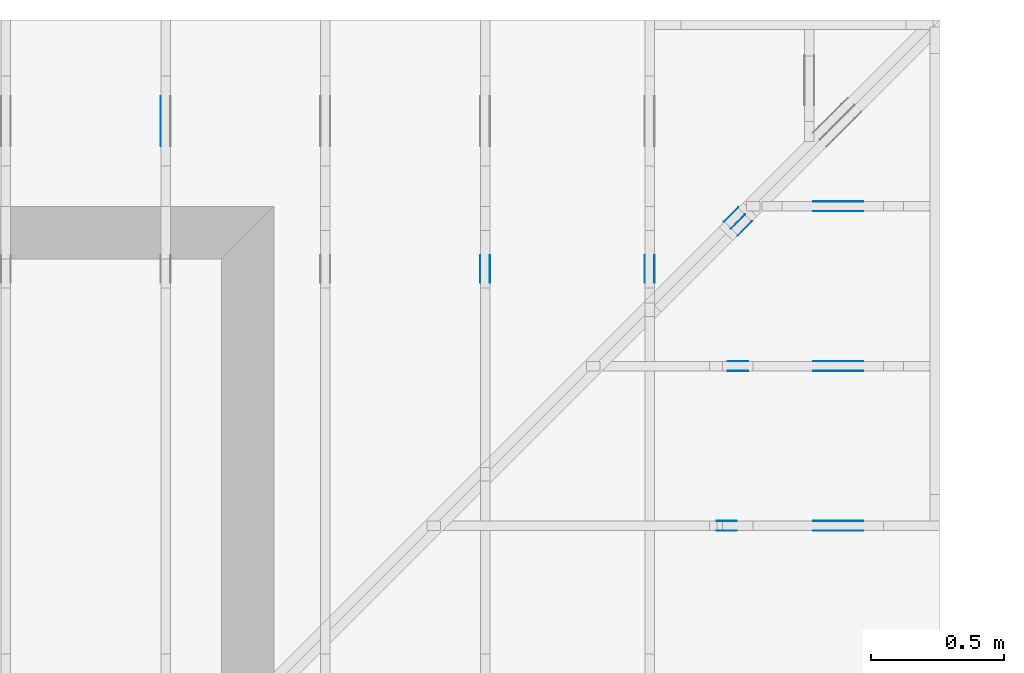
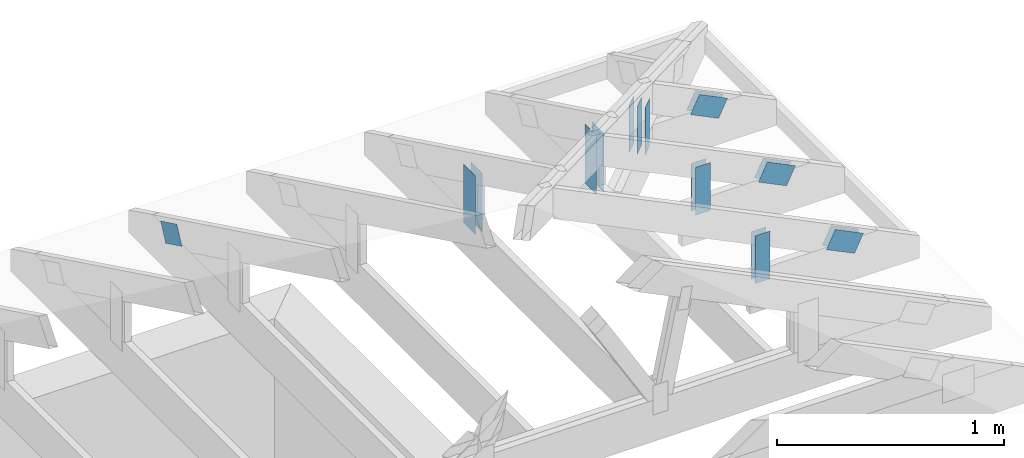
# One storey, part 138 of 159: 19 plates, 7 elements without a shape of their own.
"""IFC2X3 building model written with IfcOpenShell, lengths in millimetres."""

import ifcopenshell
import ifcopenshell.guid

model = None  # the IFC model being written
_history = None  # IfcOwnerHistory: only IFC2X3 demands one
_inside = {}  # id of a spatial element -> (the spatial element, [elements in it])
_under = {}  # id of a project, library or spatial element -> (it, [spatial elements below it])
_declared = {}  # id of a project -> (the project, [libraries it declares])
_typed = {}  # id of a type object -> (the type object, [elements of that type])
_made_of = {}  # id of a material, layer set ... -> (it, [elements and type objects made of it])


def new_model(schema):
    """Start an empty IFC model of exactly this schema.

    Asked for "IFC4X3", IfcOpenShell would pick the latest addendum, in which some entities
    have other attributes; the version numbers below select the first issue.
    IFC2X3 requires an IfcOwnerHistory on every rooted entity: one is made here for all.
    """
    global model, _history
    if schema == "IFC4X3":
        model = ifcopenshell.file(schema_version=(4, 3, 0, 0))
    else:
        model = ifcopenshell.file(schema=schema)
    _inside.clear()
    _under.clear()
    _declared.clear()
    _typed.clear()
    _made_of.clear()
    _history = None
    if model.schema == "IFC2X3":
        org = make("IfcOrganization", Name="unknown")
        user = make(
            "IfcPersonAndOrganization",
            ThePerson=make("IfcPerson", FamilyName="unknown"),
            TheOrganization=org,
        )
        app = make(
            "IfcApplication",
            ApplicationDeveloper=org,
            Version="unknown",
            ApplicationFullName="unknown",
            ApplicationIdentifier="unknown",
        )
        _history = make(
            "IfcOwnerHistory",
            OwningUser=user,
            OwningApplication=app,
            ChangeAction="ADDED",
            CreationDate=0,
        )
    return model


def make(cls, **values):
    """One entity of the class cls with the attributes given. An attribute that is None is left unset."""
    return model.create_entity(
        cls, **{name: value for name, value in values.items() if value is not None}
    )


def rooted(cls, **values):
    """An entity with a GlobalId (a new one), such as an element, a storey or a relation."""
    return make(cls, GlobalId=ifcopenshell.guid.new(), OwnerHistory=_history, **values)


def si_unit(unit_type, name, prefix=None):
    """IfcSIUnit, for example si_unit("LENGTHUNIT", "METRE", prefix="MILLI")."""
    return make("IfcSIUnit", UnitType=unit_type, Prefix=prefix, Name=name)


def assignment(units):
    """IfcUnitAssignment: the units of a project."""
    return None if units is None else make("IfcUnitAssignment", Units=units)


def point(xyz):
    """IfcCartesianPoint."""
    return None if xyz is None else make("IfcCartesianPoint", Coordinates=xyz)


def direction(xyz):
    """IfcDirection."""
    return None if xyz is None else make("IfcDirection", DirectionRatios=xyz)


def frame(location, z_axis=None, x_axis=None):
    """IfcAxis2Placement3D, a coordinate frame: its origin and axes. An axis left out is left unset."""
    return make(
        "IfcAxis2Placement3D",
        Location=point(location),
        Axis=direction(z_axis),
        RefDirection=direction(x_axis),
    )


def frame_2d(location, x_axis=None):
    """IfcAxis2Placement2D, a coordinate frame in the plane: its origin and x axis."""
    return make(
        "IfcAxis2Placement2D", Location=point(location), RefDirection=direction(x_axis)
    )


def origin():
    """The frame at (0, 0, 0) with its axes left unset."""
    return frame((0.0, 0.0, 0.0))


def origin_with_axes():
    """The frame at (0, 0, 0) with the z axis (0, 0, 1) and the x axis (1, 0, 0) written out."""
    return frame((0.0, 0.0, 0.0), z_axis=(0.0, 0.0, 1.0), x_axis=(1.0, 0.0, 0.0))


def origin_2d():
    """The frame at (0, 0) in the plane with its x axis left unset."""
    return frame_2d((0.0, 0.0))


def place(relative_to, where):
    """IfcLocalPlacement: puts the frame where relative to a parent placement (None: the world)."""
    return make(
        "IfcLocalPlacement", PlacementRelTo=relative_to, RelativePlacement=where
    )


def context(
    kind, dimensions, precision=None, world=None, true_north=None, identifier=None
):
    """IfcGeometricRepresentationContext, for example the 3D "Model" context."""
    return make(
        "IfcGeometricRepresentationContext",
        ContextIdentifier=identifier,
        ContextType=kind,
        CoordinateSpaceDimension=dimensions,
        Precision=precision,
        WorldCoordinateSystem=world,
        TrueNorth=true_north,
    )


def project(units=None, contexts=None):
    """IfcProject with its units and contexts."""
    return rooted(
        "IfcProject",
        Name="project",
        RepresentationContexts=contexts,
        UnitsInContext=assignment(units),
    )


def spatial(cls, under=None, at=None, **own):
    """A site, building, storey or space (cls), placed at a placement, below another one or the project."""
    s = rooted(cls, ObjectPlacement=at, **own)
    if under is not None:
        _under.setdefault(under.id(), (under, []))[1].append(s)
    return s


def faces_of(points, faces, orient=None, outer=None):
    """IfcFace entities. A face is a list of loops; a loop is a list of indices into points, from 0.

    orient and outer hold one flag for each loop. By default every Orientation is true, the
    first loop of a face is its IfcFaceOuterBound and the others are IfcFaceBound.
    """
    made = []
    for i, loops in enumerate(faces):
        bounds = []
        for j, loop in enumerate(loops):
            is_outer = j == 0 if outer is None else outer[i][j]
            bounds.append(
                make(
                    "IfcFaceOuterBound" if is_outer else "IfcFaceBound",
                    Bound=make("IfcPolyLoop", Polygon=[points[k] for k in loop]),
                    Orientation=True if orient is None else orient[i][j],
                )
            )
        made.append(make("IfcFace", Bounds=bounds))
    return made


def faceted_brep(points, faces, orient=None, outer=None, voids=None):
    """IfcFacetedBrep: a solid bounded by flat faces; with voids (closed shells), ...WithVoids."""
    shared = [point(p) for p in points]
    hull = make("IfcClosedShell", CfsFaces=faces_of(shared, faces, orient, outer))
    if voids is None:
        return make("IfcFacetedBrep", Outer=hull)
    return make(
        "IfcFacetedBrepWithVoids",
        Outer=hull,
        Voids=[
            make(cls, CfsFaces=faces_of(shared, fs, o, b)) for cls, fs, o, b in voids
        ],
    )


def shape(context_of_items, identifier, shape_type, items):
    """IfcShapeRepresentation: the items that make up one representation, for example the "Body"."""
    return make(
        "IfcShapeRepresentation",
        ContextOfItems=context_of_items,
        RepresentationIdentifier=identifier,
        RepresentationType=shape_type,
        Items=items,
    )


def made_of(thing, what):
    """Note that an element or type object is made of a material, layer set ...; save() writes the relation."""
    if what is not None:
        _made_of.setdefault(what.id(), (what, []))[1].append(thing)
    return thing


def element(
    cls,
    number,
    at=None,
    inside=None,
    cuts=None,
    type_object=None,
    material=None,
    context=None,
    identifier="Body",
    shape_type=None,
    held_by="IfcProductDefinitionShape",
    body=None,
    shapes=None,
    **own,
):
    """One element of the class cls, such as IfcWall. Its Tag is "e" and its number.

    at: its placement. inside: the storey or other place that contains it. cuts: it is an
    opening in that element (IfcRelVoidsElement). A single representation is given by context,
    identifier, shape_type and body (its items); several are given by shapes. held_by: the class
    of the entity that holds the representations. save() writes the other relations.
    """
    e = rooted(cls, Tag="e%d" % number, ObjectPlacement=at, **own)
    if body is not None:
        shapes = [shape(context, identifier, shape_type, body)]
    if shapes is not None:
        e.Representation = make(held_by, Representations=shapes)
    if inside is not None:
        _inside.setdefault(inside.id(), (inside, []))[1].append(e)
    if cuts is not None:
        rooted(
            "IfcRelVoidsElement", RelatingBuildingElement=cuts, RelatedOpeningElement=e
        )
    if type_object is not None:
        _typed.setdefault(type_object.id(), (type_object, []))[1].append(e)
    return made_of(e, material)


def aggregate(whole, parts):
    """IfcRelAggregates: a whole, such as a stair, and the parts it consists of."""
    return rooted("IfcRelAggregates", RelatingObject=whole, RelatedObjects=parts)


def save(model, path):
    """Write the relations noted so far, then the file.

    IfcRelAggregates (storeys below a building ...), IfcRelContainedInSpatialStructure (elements
    in a storey), IfcRelDefinesByType, IfcRelAssociatesMaterial and IfcRelDeclares: one each for
    every whole, place, type object, material and project.
    """
    for whole, parts in _under.values():
        aggregate(whole, parts)
    for where, things in _inside.values():
        rooted(
            "IfcRelContainedInSpatialStructure",
            RelatedElements=things,
            RelatingStructure=where,
        )
    for kind, things in _typed.values():
        rooted("IfcRelDefinesByType", RelatedObjects=things, RelatingType=kind)
    for what, things in _made_of.values():
        rooted("IfcRelAssociatesMaterial", RelatedObjects=things, RelatingMaterial=what)
    for by, libraries in _declared.values():
        rooted("IfcRelDeclares", RelatingContext=by, RelatedDefinitions=libraries)
    model.write(path)


model = new_model("IFC2X3")

# Units and contexts
model_context = context("Model", 3, precision=1e-05, world=origin())
plan_context = context("Plan", 2, precision=1e-05, world=origin_2d())
ifc_project = project(units=[si_unit("LENGTHUNIT", "METRE", prefix="MILLI"), si_unit("AREAUNIT", "SQUARE_METRE"), si_unit("VOLUMEUNIT", "CUBIC_METRE"), si_unit("SOLIDANGLEUNIT", "STERADIAN"), si_unit("PLANEANGLEUNIT", "RADIAN"), si_unit("MASSUNIT", "GRAM"), si_unit("TIMEUNIT", "SECOND"), si_unit("THERMODYNAMICTEMPERATUREUNIT", "DEGREE_CELSIUS"), si_unit("LUMINOUSINTENSITYUNIT", "LUMEN")], contexts=[model_context, plan_context])

# Site, building, storey
site_placement = place(None, origin_with_axes())
site = spatial("IfcSite", under=ifc_project, at=site_placement, CompositionType="ELEMENT")
building_placement = place(site_placement, origin_with_axes())
building = spatial("IfcBuilding", under=site, at=building_placement, Name="Plan 1", CompositionType="ELEMENT")
storey_placement = place(building_placement, origin_with_axes())
storey = spatial("IfcBuildingStorey", under=building, at=storey_placement, Name="Etasje 1", CompositionType="ELEMENT", Elevation=0.0)

# Assembly, plates
assembly_1_placement = place(storey_placement, frame((19174.556818978774, 13925.455822662876, 2.204291436880279e-15), z_axis=(-0.7071067811865465, 0.7071067811865486, 6.123031769111886e-17), x_axis=(-0.7071067811865486, -0.7071067811865465, 0.0)))
assembly_1 = element("IfcElementAssembly", 1, at=assembly_1_placement, inside=storey, Name="GR3 (58)", AssemblyPlace="FACTORY", PredefinedType="TRUSS")
plate_1_placement = place(assembly_1_placement, frame((1108.8371583767168, 145.77349853515625, 0.0), z_axis=(0.0, 0.0, 1.0), x_axis=(6.123031769111886e-17, 1.0, 0.0)))
plate_1 = element("IfcPlate", 2, at=plate_1_placement, Name="GNT100S 76x258", context=model_context, shape_type="Brep", body=[
    faceted_brep([(258.0, 76.00000017359184, 1.0), (0.0, 76.00000017359184, 1.0), (0.0, 1.7359184312226716e-07, 1.0), (258.0, 1.7359184312226716e-07, 1.0), (0.0, 76.00000017359184, 0.0), (258.0, 76.00000017359184, 3.1594843928617333e-14), (258.0, 1.7359184312226716e-07, 3.1594843928617333e-14), (0.0, 1.7359184312226716e-07, 0.0), (258.0000011275676, -4.739226610004997e-14, 2.9018435094081024e-30), (258.0000011275676, -4.733103578235885e-14, 1.0), (1.127567600178736e-06, 6.123011056715174e-17, 1.0), (1.127567600178736e-06, -2.071239671314695e-22, 1.268226630890474e-38), (258.0000011275676, 76.0, 0.0), (258.0000011275676, 76.0, 1.0), (258.0000011275676, 0.0, 1.0), (258.0000011275676, 0.0, 0.0), (1.127567600178736e-06, 76.0, 0.0), (1.127567600178736e-06, 76.0, 1.0), (258.0000011275676, 75.99999999999999, 1.0), (258.0000011275676, 75.99999999999999, -7.888609052210118e-31), (1.127567600178736e-06, 0.0, 0.0), (1.1275676002399663e-06, -7.498303609110687e-33, 1.0), (1.1275676095469746e-06, 76.0, 1.0), (1.1275676094857443e-06, 76.0, -5.69871080169884e-31)], [[[0, 1, 2, 3]], [[4, 5, 6, 7]], [[8, 9, 10, 11]], [[12, 13, 14, 15]], [[16, 17, 18, 19]], [[20, 21, 22, 23]]]),
])
plate_2_placement = place(assembly_1_placement, frame((1108.8371583767168, 145.77349853515625, -37.0), z_axis=(0.0, 0.0, 1.0), x_axis=(6.123031769111886e-17, 1.0, 0.0)))
plate_2 = element("IfcPlate", 3, at=plate_2_placement, Name="GNT100S 76x258", context=model_context, shape_type="Brep", body=[
    faceted_brep([(258.0, 76.00000017359184, 1.0), (0.0, 76.00000017359184, 1.0), (0.0, 1.7359184312226716e-07, 1.0), (258.0, 1.7359184312226716e-07, 1.0), (0.0, 76.00000017359184, 0.0), (258.0, 76.00000017359184, 3.1594843928617333e-14), (258.0, 1.7359184312226716e-07, 3.1594843928617333e-14), (0.0, 1.7359184312226716e-07, 0.0), (258.0000011275676, -4.739226610004997e-14, 2.9018435094081024e-30), (258.0000011275676, -4.733103578235885e-14, 1.0), (1.127567600178736e-06, 6.123011056715174e-17, 1.0), (1.127567600178736e-06, -2.071239671314695e-22, 1.268226630890474e-38), (258.0000011275676, 76.0, 0.0), (258.0000011275676, 76.0, 1.0), (258.0000011275676, 0.0, 1.0), (258.0000011275676, 0.0, 0.0), (1.127567600178736e-06, 76.0, 0.0), (1.127567600178736e-06, 76.0, 1.0), (258.0000011275676, 75.99999999999999, 1.0), (258.0000011275676, 75.99999999999999, -7.888609052210118e-31), (1.127567600178736e-06, 0.0, 0.0), (1.1275676002399663e-06, -7.498303609110687e-33, 1.0), (1.1275676095469746e-06, 76.0, 1.0), (1.1275676094857443e-06, 76.0, -5.69871080169884e-31)], [[[0, 1, 2, 3]], [[4, 5, 6, 7]], [[8, 9, 10, 11]], [[12, 13, 14, 15]], [[16, 17, 18, 19]], [[20, 21, 22, 23]]]),
])
plate_3_placement = place(assembly_1_placement, frame((1108.8371583767168, 145.77349853515625, -36.0), z_axis=(0.0, 0.0, 1.0), x_axis=(6.123031769111886e-17, 1.0, 0.0)))
plate_3 = element("IfcPlate", 4, at=plate_3_placement, Name="GNT100S 76x258", context=model_context, shape_type="Brep", body=[
    faceted_brep([(258.0, 76.00000017359184, 1.0), (0.0, 76.00000017359184, 1.0), (0.0, 1.7359184312226716e-07, 1.0), (258.0, 1.7359184312226716e-07, 1.0), (0.0, 76.00000017359184, 0.0), (258.0, 76.00000017359184, 3.1594843928617333e-14), (258.0, 1.7359184312226716e-07, 3.1594843928617333e-14), (0.0, 1.7359184312226716e-07, 0.0), (258.0000011275676, -4.739226610004997e-14, 2.9018435094081024e-30), (258.0000011275676, -4.733103578235885e-14, 1.0), (1.127567600178736e-06, 6.123011056715174e-17, 1.0), (1.127567600178736e-06, -2.071239671314695e-22, 1.268226630890474e-38), (258.0000011275676, 76.0, 0.0), (258.0000011275676, 76.0, 1.0), (258.0000011275676, 0.0, 1.0), (258.0000011275676, 0.0, 0.0), (1.127567600178736e-06, 76.0, 0.0), (1.127567600178736e-06, 76.0, 1.0), (258.0000011275676, 75.99999999999999, 1.0), (258.0000011275676, 75.99999999999999, -7.888609052210118e-31), (1.127567600178736e-06, 0.0, 0.0), (1.1275676002399663e-06, -7.498303609110687e-33, 1.0), (1.1275676095469746e-06, 76.0, 1.0), (1.1275676094857443e-06, 76.0, -5.69871080169884e-31)], [[[0, 1, 2, 3]], [[4, 5, 6, 7]], [[8, 9, 10, 11]], [[12, 13, 14, 15]], [[16, 17, 18, 19]], [[20, 21, 22, 23]]]),
])
plate_4_placement = place(assembly_1_placement, frame((1108.8371583767168, 145.77349853515625, -73.0), z_axis=(0.0, 0.0, 1.0), x_axis=(6.123031769111886e-17, 1.0, 0.0)))
plate_4 = element("IfcPlate", 5, at=plate_4_placement, Name="GNT100S 76x258", context=model_context, shape_type="Brep", body=[
    faceted_brep([(258.0, 76.00000017359184, 1.0), (0.0, 76.00000017359184, 1.0), (0.0, 1.7359184312226716e-07, 1.0), (258.0, 1.7359184312226716e-07, 1.0), (0.0, 76.00000017359184, 0.0), (258.0, 76.00000017359184, 3.1594843928617333e-14), (258.0, 1.7359184312226716e-07, 3.1594843928617333e-14), (0.0, 1.7359184312226716e-07, 0.0), (258.0000011275676, -4.739226610004997e-14, 2.9018435094081024e-30), (258.0000011275676, -4.733103578235885e-14, 1.0), (1.127567600178736e-06, 6.123011056715174e-17, 1.0), (1.127567600178736e-06, -2.071239671314695e-22, 1.268226630890474e-38), (258.0000011275676, 76.0, 0.0), (258.0000011275676, 76.0, 1.0), (258.0000011275676, 0.0, 1.0), (258.0000011275676, 0.0, 0.0), (1.127567600178736e-06, 76.0, 0.0), (1.127567600178736e-06, 76.0, 1.0), (258.0000011275676, 75.99999999999999, 1.0), (258.0000011275676, 75.99999999999999, -7.888609052210118e-31), (1.127567600178736e-06, 0.0, 0.0), (1.1275676002399663e-06, -7.498303609110687e-33, 1.0), (1.1275676095469746e-06, 76.0, 1.0), (1.1275676094857443e-06, 76.0, -5.69871080169884e-31)], [[[0, 1, 2, 3]], [[4, 5, 6, 7]], [[8, 9, 10, 11]], [[12, 13, 14, 15]], [[16, 17, 18, 19]], [[20, 21, 22, 23]]]),
])
aggregate(assembly_1, [plate_1, plate_2, plate_3, plate_4])

# Assembly, plate
assembly_2_placement = place(storey_placement, frame((16275.022261404762, 13899.999978540158, 1.1021457184401395e-15), z_axis=(-1.0, 1.836909530733566e-16, 6.123031769111886e-17), x_axis=(-1.836909530733566e-16, -1.0, 0.0)))
assembly_2 = element("IfcElementAssembly", 6, at=assembly_2_placement, inside=storey, Name="S39 (62)", AssemblyPlace="FACTORY", PredefinedType="TRUSS")
plate_5_placement = place(assembly_2_placement, frame((331.11001837024, 141.86159042510417, 0.0), z_axis=(0.0, 0.0, 1.0), x_axis=(0.8987940462991671, 0.4383711467890776, 0.0)))
plate_5 = element("IfcPlate", 7, at=plate_5_placement, Name="GNT100S 103x159", context=model_context, shape_type="Brep", body=[
    faceted_brep([(158.99998918476695, 103.00001264929413, 1.0), (1.0551442528594634e-05, 103.00001264929413, 1.0), (3.169460796925705e-06, 1.2203795577647725e-05, 1.0), (159.00000923180278, 1.2203795577647725e-05, 1.0), (1.0551442528594634e-05, 103.00001264929413, 1.292136356250864e-21), (158.99998918476695, 103.00001264929413, 1.9471239701335487e-14), (159.00000923180278, 0.0, 1.9471242156308234e-14), (3.169460796925705e-06, 0.0, 3.8813418301061536e-22), (159.0, 1.1149114086276055e-05, 9.182102347154389e-31), (159.0, 1.1149114086337285e-05, 1.0), (5.684341886080801e-14, 1.1149114115544147e-05, 1.0), (5.684341886080801e-14, 1.1149114115482917e-05, 0.0), (159.0, 103.00001114911404, -6.310887241768095e-30), (159.0, 103.00001114911404, 1.0), (159.0, 1.1149114101272062e-05, 1.0), (159.0, 1.1149114101272062e-05, 0.0), (0.0, 103.00001114911412, 0.0), (0.0, 103.00001114911412, 1.0), (159.0000000000001, 103.00001114911403, 1.0), (159.0000000000001, 103.00001114911403, 0.0), (5.684342142788349e-14, 1.1149114115482917e-05, -1.5718284720059314e-37), (5.690465174557461e-14, 1.1149114115482917e-05, 1.0), (2.3776908575388652e-14, 103.00001114911412, 1.0), (2.3715678257697533e-14, 103.00001114911412, -1.4521185139791801e-30)], [[[0, 1, 2, 3]], [[4, 5, 6, 7]], [[8, 9, 10, 11]], [[12, 13, 14, 15]], [[16, 17, 18, 19]], [[20, 21, 22, 23]]]),
])
aggregate(assembly_2, [plate_5])

# Assembly, plates
assembly_3_placement = place(storey_placement, frame((17475.02226140476, 13899.999978540158, 1.1021457184401395e-15), z_axis=(-1.0, 1.836909530733566e-16, 6.123031769111886e-17), x_axis=(-1.836909530733566e-16, -1.0, 0.0)))
assembly_3 = element("IfcElementAssembly", 8, at=assembly_3_placement, inside=storey, Name="S41 (67)", AssemblyPlace="FACTORY", PredefinedType="TRUSS")
plate_6_placement = place(assembly_3_placement, frame((986.0125131972018, 165.43966674804688, 0.0), z_axis=(0.0, 0.0, 1.0), x_axis=(6.123031769111886e-17, 1.0, 0.0)))
plate_6 = element("IfcPlate", 9, at=plate_6_placement, Name="GNT100S 103x317", context=model_context, shape_type="Brep", body=[
    faceted_brep([(317.0, 103.00000099017052, 1.0), (0.0, 103.00000099017052, 1.0), (0.0, 9.90170519798994e-07, 1.0), (317.0, 9.90170519798994e-07, 1.0), (0.0, 103.00000099017052, 0.0), (317.0, 103.00000099017052, 3.882002141616936e-14), (317.0, 9.90170519798994e-07, 3.882002141616936e-14), (0.0, 9.90170519798994e-07, 0.0), (317.00000586341474, -5.823003320131028e-14, 3.565443432080628e-30), (317.00000586341474, -5.816880288361916e-14, 1.0), (5.863414742179884e-06, 6.122924063487661e-17, 1.0), (5.863414742179884e-06, -1.0770562422553924e-21, 6.594849588450035e-38), (317.00000586341474, 103.0, 0.0), (317.00000586341474, 103.0, 1.0), (317.00000586341474, 0.0, 1.0), (317.00000586341474, 0.0, 0.0), (5.863414742179884e-06, 103.0, 0.0), (5.863414742179884e-06, 103.0, 1.0), (317.00000586341474, 102.99999999999999, 1.0), (317.00000586341474, 102.99999999999999, -1.5777218104420236e-30), (5.863414742179884e-06, 0.0, 0.0), (5.863414742241115e-06, -7.498303609110687e-33, 1.0), (5.86341475485456e-06, 103.0, 1.0), (5.86341475479333e-06, 103.0, -7.723252732077687e-31)], [[[0, 1, 2, 3]], [[4, 5, 6, 7]], [[8, 9, 10, 11]], [[12, 13, 14, 15]], [[16, 17, 18, 19]], [[20, 21, 22, 23]]]),
])
plate_7_placement = place(assembly_3_placement, frame((986.0125131972018, 165.43966674804688, -37.0), z_axis=(0.0, 0.0, 1.0), x_axis=(6.123031769111886e-17, 1.0, 0.0)))
plate_7 = element("IfcPlate", 10, at=plate_7_placement, Name="GNT100S 103x317", context=model_context, shape_type="Brep", body=[
    faceted_brep([(317.0, 103.00000099017052, 1.0), (0.0, 103.00000099017052, 1.0), (0.0, 9.90170519798994e-07, 1.0), (317.0, 9.90170519798994e-07, 1.0), (0.0, 103.00000099017052, 0.0), (317.0, 103.00000099017052, 3.882002141616936e-14), (317.0, 9.90170519798994e-07, 3.882002141616936e-14), (0.0, 9.90170519798994e-07, 0.0), (317.00000586341474, -5.823003320131028e-14, 3.565443432080628e-30), (317.00000586341474, -5.816880288361916e-14, 1.0), (5.863414742179884e-06, 6.122924063487661e-17, 1.0), (5.863414742179884e-06, -1.0770562422553924e-21, 6.594849588450035e-38), (317.00000586341474, 103.0, 0.0), (317.00000586341474, 103.0, 1.0), (317.00000586341474, 0.0, 1.0), (317.00000586341474, 0.0, 0.0), (5.863414742179884e-06, 103.0, 0.0), (5.863414742179884e-06, 103.0, 1.0), (317.00000586341474, 102.99999999999999, 1.0), (317.00000586341474, 102.99999999999999, -1.5777218104420236e-30), (5.863414742179884e-06, 0.0, 0.0), (5.863414742241115e-06, -7.498303609110687e-33, 1.0), (5.86341475485456e-06, 103.0, 1.0), (5.86341475479333e-06, 103.0, -7.723252732077687e-31)], [[[0, 1, 2, 3]], [[4, 5, 6, 7]], [[8, 9, 10, 11]], [[12, 13, 14, 15]], [[16, 17, 18, 19]], [[20, 21, 22, 23]]]),
])
aggregate(assembly_3, [plate_6, plate_7])

assembly_4_placement = place(storey_placement, frame((19200.01266310149, 12017.999978540158, 1.1021457184401395e-15), z_axis=(1.2246063538223773e-16, 1.0, 6.123031769111886e-17), x_axis=(-1.0, 1.2246063538223773e-16, 0.0)))
assembly_4 = element("IfcElementAssembly", 11, at=assembly_4_placement, inside=storey, Name="S45 (74)", AssemblyPlace="FACTORY", PredefinedType="TRUSS")
plate_8_placement = place(assembly_4_placement, frame((331.1100183702398, 141.86159042510405, 0.0), z_axis=(0.0, 0.0, 1.0), x_axis=(0.8987940462991671, 0.4383711467890776, 0.0)))
plate_8 = element("IfcPlate", 12, at=plate_8_placement, Name="GNT100S 103x159", context=model_context, shape_type="Brep", body=[
    faceted_brep([(158.99998918476717, 103.00001264929413, 1.0), (1.055144275596831e-05, 103.00001264929413, 1.0), (3.1694610242993804e-06, 1.2203795577647725e-05, 1.0), (159.000009231803, 1.2203795577647725e-05, 1.0), (1.055144275596831e-05, 103.00001264929413, 1.2921363840951888e-21), (158.99998918476717, 103.00001264929413, 1.9471239701335515e-14), (159.000009231803, 0.0, 1.947124215630826e-14), (3.1694610242993804e-06, 0.0, 3.8813421085494012e-22), (159.0, 1.1149113574685285e-05, 9.182102347154389e-31), (159.0, 1.1149113574746516e-05, 1.0), (5.684341886080802e-14, 1.1149113603953377e-05, 1.0), (5.684341886080802e-14, 1.1149113603892147e-05, 0.0), (159.0, 103.00001114911353, 0.0), (159.0, 103.00001114911353, 1.0), (159.0, 1.1149113589681292e-05, 1.0), (159.0, 1.1149113589681292e-05, 0.0), (0.0, 103.0000111491136, 0.0), (0.0, 103.0000111491136, 1.0), (159.0, 103.00001114911352, 1.0), (159.0, 103.00001114911352, -7.888609052210118e-31), (5.684342142788336e-14, 1.1149113603892147e-05, -1.5718284019410082e-37), (5.690465174557448e-14, 1.1149113603892147e-05, 1.0), (2.3776908575388526e-14, 103.0000111491136, 1.0), (2.3715678257697407e-14, 103.0000111491136, -1.4521185139791728e-30)], [[[0, 1, 2, 3]], [[4, 5, 6, 7]], [[8, 9, 10, 11]], [[12, 13, 14, 15]], [[16, 17, 18, 19]], [[20, 21, 22, 23]]]),
])
plate_9_placement = place(assembly_4_placement, frame((331.1100183702398, 141.86159042510405, -37.00000000000001), z_axis=(0.0, 0.0, 1.0), x_axis=(0.8987940462991671, 0.4383711467890776, 0.0)))
plate_9 = element("IfcPlate", 13, at=plate_9_placement, Name="GNT100S 103x159", context=model_context, shape_type="Brep", body=[
    faceted_brep([(158.99998918476717, 103.00001264929413, 1.0), (1.055144275596831e-05, 103.00001264929413, 1.0), (3.1694610242993804e-06, 1.2203795577647725e-05, 1.0), (159.000009231803, 1.2203795577647725e-05, 1.0), (1.055144275596831e-05, 103.00001264929413, 1.2921363840951888e-21), (158.99998918476717, 103.00001264929413, 1.9471239701335515e-14), (159.000009231803, 0.0, 1.947124215630826e-14), (3.1694610242993804e-06, 0.0, 3.8813421085494012e-22), (159.0, 1.1149113574685285e-05, 9.182102347154389e-31), (159.0, 1.1149113574746516e-05, 1.0), (5.684341886080802e-14, 1.1149113603953377e-05, 1.0), (5.684341886080802e-14, 1.1149113603892147e-05, 0.0), (159.0, 103.00001114911353, 0.0), (159.0, 103.00001114911353, 1.0), (159.0, 1.1149113589681292e-05, 1.0), (159.0, 1.1149113589681292e-05, 0.0), (0.0, 103.0000111491136, 0.0), (0.0, 103.0000111491136, 1.0), (159.0, 103.00001114911352, 1.0), (159.0, 103.00001114911352, -7.888609052210118e-31), (5.684342142788336e-14, 1.1149113603892147e-05, -1.5718284019410082e-37), (5.690465174557448e-14, 1.1149113603892147e-05, 1.0), (2.3776908575388526e-14, 103.0000111491136, 1.0), (2.3715678257697407e-14, 103.0000111491136, -1.4521185139791728e-30)], [[[0, 1, 2, 3]], [[4, 5, 6, 7]], [[8, 9, 10, 11]], [[12, 13, 14, 15]], [[16, 17, 18, 19]], [[20, 21, 22, 23]]]),
])
plate_10_placement = place(assembly_4_placement, frame((837.0, 155.0166255368876, 0.0), z_axis=(0.0, 0.0, 1.0), x_axis=(6.123031769111886e-17, 1.0, 0.0)))
plate_10 = element("IfcPlate", 14, at=plate_10_placement, Name="GNT100S 76x258", context=model_context, shape_type="Brep", body=[
    faceted_brep([(258.0000065431905, 76.0, 1.0), (6.543190522734221e-06, 76.0, 1.0), (6.543190522734221e-06, 0.0, 1.0), (258.0000065431905, 0.0, 1.0), (6.543190522734221e-06, 76.0, 8.012832688410689e-22), (258.0000065431905, 76.0, 3.15948447299006e-14), (258.0000065431905, 0.0, 3.15948447299006e-14), (6.543190522734221e-06, 0.0, 8.012832688410689e-22), (258.0, -4.7392265892926e-14, 2.901843496725836e-30), (258.0, -4.733103557523488e-14, 1.0), (1.1247455413666031e-32, 6.123031769111886e-17, 1.0), (0.0, 0.0, 0.0), (258.0, 76.0, 0.0), (258.0, 76.0, 1.0), (258.0, 0.0, 1.0), (258.0, 0.0, 0.0), (0.0, 76.0, 0.0), (-3.7491518045553436e-33, 76.0, 1.0), (258.0, 75.99999999999999, 1.0), (258.0, 75.99999999999999, -7.888609052210118e-31), (0.0, 0.0, 0.0), (6.123031769111886e-17, -7.498303609110687e-33, 1.0), (9.368238606741186e-15, 76.0, 1.0), (9.307008289050067e-15, 76.0, -5.698710742924122e-31)], [[[0, 1, 2, 3]], [[4, 5, 6, 7]], [[8, 9, 10, 11]], [[12, 13, 14, 15]], [[16, 17, 18, 19]], [[20, 21, 22, 23]]]),
])
plate_11_placement = place(assembly_4_placement, frame((837.0, 155.0166255368876, -37.0), z_axis=(0.0, 0.0, 1.0), x_axis=(6.123031769111886e-17, 1.0, 0.0)))
plate_11 = element("IfcPlate", 15, at=plate_11_placement, Name="GNT100S 76x258", context=model_context, shape_type="Brep", body=[
    faceted_brep([(258.0000065431905, 76.0, 1.0), (6.543190522734221e-06, 76.0, 1.0), (6.543190522734221e-06, 0.0, 1.0), (258.0000065431905, 0.0, 1.0), (6.543190522734221e-06, 76.0, 8.012832688410689e-22), (258.0000065431905, 76.0, 3.15948447299006e-14), (258.0000065431905, 0.0, 3.15948447299006e-14), (6.543190522734221e-06, 0.0, 8.012832688410689e-22), (258.0, -4.7392265892926e-14, 2.901843496725836e-30), (258.0, -4.733103557523488e-14, 1.0), (1.1247455413666031e-32, 6.123031769111886e-17, 1.0), (0.0, 0.0, 0.0), (258.0, 76.0, 0.0), (258.0, 76.0, 1.0), (258.0, 0.0, 1.0), (258.0, 0.0, 0.0), (0.0, 76.0, 0.0), (-3.7491518045553436e-33, 76.0, 1.0), (258.0, 75.99999999999999, 1.0), (258.0, 75.99999999999999, -7.888609052210118e-31), (0.0, 0.0, 0.0), (6.123031769111886e-17, -7.498303609110687e-33, 1.0), (9.368238606741186e-15, 76.0, 1.0), (9.307008289050067e-15, 76.0, -5.698710742924122e-31)], [[[0, 1, 2, 3]], [[4, 5, 6, 7]], [[8, 9, 10, 11]], [[12, 13, 14, 15]], [[16, 17, 18, 19]], [[20, 21, 22, 23]]]),
])
aggregate(assembly_4, [plate_8, plate_9, plate_10, plate_11])

assembly_5_placement = place(storey_placement, frame((19164.01266310149, 12617.999978540158, 1.1021457184401395e-15), z_axis=(1.2246063538223773e-16, 1.0, 6.123031769111886e-17), x_axis=(-1.0, 1.2246063538223773e-16, 0.0)))
assembly_5 = element("IfcElementAssembly", 16, at=assembly_5_placement, inside=storey, Name="S44 (75)", AssemblyPlace="FACTORY", PredefinedType="TRUSS")
plate_12_placement = place(assembly_5_placement, frame((295.11001552729476, 141.86158903850722, 0.0), z_axis=(0.0, 0.0, 1.0), x_axis=(0.8987940462991671, 0.438371146789077, 0.0)))
plate_12 = element("IfcPlate", 17, at=plate_12_placement, Name="GNT100S 103x159", context=model_context, shape_type="Brep", body=[
    faceted_brep([(158.99999234783314, 103.0000193383069, 1.0), (0.0, 103.0000193383069, 1.0), (6.332527107133501e-06, 1.2203795478171742e-05, 1.0), (159.00001239486903, 1.2203795478171742e-05, 1.0), (0.0, 103.0000193383069, 0.0), (158.99999234783314, 103.0000193383069, 1.9471240088686582e-14), (159.00001239486903, 0.0, 1.9471242543659335e-14), (6.332527107133501e-06, 0.0, 7.754852931148123e-22), (159.00000316222895, 1.1149522520451425e-05, 1.78834547762914e-30), (159.00000316222895, 1.1149522520512655e-05, 1.0), (3.1622290066479763e-06, 1.1149522549719516e-05, 1.0), (3.1622290066479763e-06, 1.1149522549658286e-05, 0.0), (159.00000316222895, 103.00001114952255, 0.0), (159.00000316222895, 103.00001114952255, 1.0), (159.00000316222895, 1.1149522549658286e-05, 1.0), (159.00000316222895, 1.1149522549658286e-05, 0.0), (3.1622290066479763e-06, 103.00001114952255, 0.0), (3.1622290066479763e-06, 103.00001114952255, 1.0), (159.00000316222895, 103.00001114952254, 1.0), (159.00000316222895, 103.00001114952254, -7.888609052210118e-31), (3.1622290066479776e-06, 1.1149522549658286e-05, -9.4039548065783e-38), (3.162229006709208e-06, 1.1149522549658286e-05, 1.0), (3.1622290193226534e-06, 103.00001114952255, 1.0), (3.162229019261423e-06, 103.00001114952255, -7.723253437374298e-31)], [[[0, 1, 2, 3]], [[4, 5, 6, 7]], [[8, 9, 10, 11]], [[12, 13, 14, 15]], [[16, 17, 18, 19]], [[20, 21, 22, 23]]]),
])
plate_13_placement = place(assembly_5_placement, frame((295.11001552729476, 141.86158903850722, -36.99999999999999), z_axis=(0.0, 0.0, 1.0), x_axis=(0.8987940462991671, 0.438371146789077, 0.0)))
plate_13 = element("IfcPlate", 18, at=plate_13_placement, Name="GNT100S 103x159", context=model_context, shape_type="Brep", body=[
    faceted_brep([(158.99999234783314, 103.0000193383069, 1.0), (0.0, 103.0000193383069, 1.0), (6.332527107133501e-06, 1.2203795478171742e-05, 1.0), (159.00001239486903, 1.2203795478171742e-05, 1.0), (0.0, 103.0000193383069, 0.0), (158.99999234783314, 103.0000193383069, 1.9471240088686582e-14), (159.00001239486903, 0.0, 1.9471242543659335e-14), (6.332527107133501e-06, 0.0, 7.754852931148123e-22), (159.00000316222895, 1.1149522520451425e-05, 1.78834547762914e-30), (159.00000316222895, 1.1149522520512655e-05, 1.0), (3.1622290066479763e-06, 1.1149522549719516e-05, 1.0), (3.1622290066479763e-06, 1.1149522549658286e-05, 0.0), (159.00000316222895, 103.00001114952255, 0.0), (159.00000316222895, 103.00001114952255, 1.0), (159.00000316222895, 1.1149522549658286e-05, 1.0), (159.00000316222895, 1.1149522549658286e-05, 0.0), (3.1622290066479763e-06, 103.00001114952255, 0.0), (3.1622290066479763e-06, 103.00001114952255, 1.0), (159.00000316222895, 103.00001114952254, 1.0), (159.00000316222895, 103.00001114952254, -7.888609052210118e-31), (3.1622290066479776e-06, 1.1149522549658286e-05, -9.4039548065783e-38), (3.162229006709208e-06, 1.1149522549658286e-05, 1.0), (3.1622290193226534e-06, 103.00001114952255, 1.0), (3.162229019261423e-06, 103.00001114952255, -7.723253437374298e-31)], [[[0, 1, 2, 3]], [[4, 5, 6, 7]], [[8, 9, 10, 11]], [[12, 13, 14, 15]], [[16, 17, 18, 19]], [[20, 21, 22, 23]]]),
])
plate_14_placement = place(assembly_5_placement, frame((759.5000000000036, 144.89617432448998, 0.0), z_axis=(0.0, 0.0, 1.0), x_axis=(6.123031769111886e-17, 1.0, 0.0)))
plate_14 = element("IfcPlate", 19, at=plate_14_placement, Name="GNT100S 76x258", context=model_context, shape_type="Brep", body=[
    faceted_brep([(258.0000048747288, 76.00000000000364, 1.0), (4.874728745107859e-06, 76.00000000000364, 1.0), (4.8747287735295686e-06, 3.637978807091713e-12, 1.0), (258.0000048747288, 3.637978807091713e-12, 1.0), (4.874728745107859e-06, 76.00000000000364, 5.969623794419668e-22), (258.0000048747288, 76.00000000000364, 3.159484452557972e-14), (258.0000048747288, 3.637978807091713e-12, 3.159484452557972e-14), (4.8747287735295686e-06, 3.637978807091713e-12, 5.969623829225074e-22), (258.0, -4.7392265892926e-14, 2.901843496725836e-30), (258.0, -4.733103557523488e-14, 1.0), (2.842170943040401e-14, 6.123031769111364e-17, 1.0), (2.842170943040401e-14, -5.220810893244919e-30, 3.1967190959864043e-46), (258.0, 76.0, 0.0), (258.0, 76.0, 1.0), (258.0, 0.0, 1.0), (258.0, 0.0, 0.0), (0.0, 76.0, 0.0), (-3.7491518045553436e-33, 76.0, 1.0), (258.0, 75.99999999999999, 1.0), (258.0, 75.99999999999999, -7.888609052210118e-31), (2.842170943040401e-14, 0.0, 0.0), (2.8482939748095126e-14, 1.96934197932066e-32, 1.0), (4.039168088540435e-15, 76.0, 1.0), (3.977937770849316e-15, 76.0, -2.435703934646048e-31)], [[[0, 1, 2, 3]], [[4, 5, 6, 7]], [[8, 9, 10, 11]], [[12, 13, 14, 15]], [[16, 17, 18, 19]], [[20, 21, 22, 23]]]),
])
plate_15_placement = place(assembly_5_placement, frame((759.5000000000036, 144.89617432448998, -37.0), z_axis=(0.0, 0.0, 1.0), x_axis=(6.123031769111886e-17, 1.0, 0.0)))
plate_15 = element("IfcPlate", 20, at=plate_15_placement, Name="GNT100S 76x258", context=model_context, shape_type="Brep", body=[
    faceted_brep([(258.0000048747288, 76.00000000000364, 1.0), (4.874728745107859e-06, 76.00000000000364, 1.0), (4.8747287735295686e-06, 3.637978807091713e-12, 1.0), (258.0000048747288, 3.637978807091713e-12, 1.0), (4.874728745107859e-06, 76.00000000000364, 5.969623794419668e-22), (258.0000048747288, 76.00000000000364, 3.159484452557972e-14), (258.0000048747288, 3.637978807091713e-12, 3.159484452557972e-14), (4.8747287735295686e-06, 3.637978807091713e-12, 5.969623829225074e-22), (258.0, -4.7392265892926e-14, 2.901843496725836e-30), (258.0, -4.733103557523488e-14, 1.0), (2.842170943040401e-14, 6.123031769111364e-17, 1.0), (2.842170943040401e-14, -5.220810893244919e-30, 3.1967190959864043e-46), (258.0, 76.0, 0.0), (258.0, 76.0, 1.0), (258.0, 0.0, 1.0), (258.0, 0.0, 0.0), (0.0, 76.0, 0.0), (-3.7491518045553436e-33, 76.0, 1.0), (258.0, 75.99999999999999, 1.0), (258.0, 75.99999999999999, -7.888609052210118e-31), (2.842170943040401e-14, 0.0, 0.0), (2.8482939748095126e-14, 1.96934197932066e-32, 1.0), (4.039168088540435e-15, 76.0, 1.0), (3.977937770849316e-15, 76.0, -2.435703934646048e-31)], [[[0, 1, 2, 3]], [[4, 5, 6, 7]], [[8, 9, 10, 11]], [[12, 13, 14, 15]], [[16, 17, 18, 19]], [[20, 21, 22, 23]]]),
])
aggregate(assembly_5, [plate_12, plate_13, plate_14, plate_15])

assembly_6_placement = place(storey_placement, frame((18093.02226140476, 13899.9999785399, 1.1021457184401395e-15), z_axis=(-1.0, -1.4305706115156844e-11, 6.123031769111886e-17), x_axis=(1.4305706115156844e-11, -1.0, 0.0)))
assembly_6 = element("IfcElementAssembly", 21, at=assembly_6_placement, inside=storey, Name="S42 (81)", AssemblyPlace="FACTORY", PredefinedType="TRUSS")
plate_16_placement = place(assembly_6_placement, frame((986.012513196707, 165.43966674804688, 0.0), z_axis=(0.0, 0.0, 1.0), x_axis=(6.123031769111886e-17, 1.0, 0.0)))
plate_16 = element("IfcPlate", 22, at=plate_16_placement, Name="GNT100S 103x317", context=model_context, shape_type="Brep", body=[
    faceted_brep([(317.0, 103.00000098967575, 1.0), (0.0, 103.00000098967575, 1.0), (0.0, 9.896757546812296e-07, 1.0), (317.0, 9.896757546812296e-07, 1.0), (0.0, 103.00000098967575, 0.0), (317.0, 103.00000098967575, 3.882002141616936e-14), (317.0, 9.896757546812296e-07, 3.882002141616936e-14), (0.0, 9.896757546812296e-07, 0.0), (317.00000586329725, -5.82300332012887e-14, 3.565443432079306e-30), (317.00000586329725, -5.816880288359758e-14, 1.0), (5.863297246833099e-06, 6.122924065645944e-17, 1.0), (5.863297246833099e-06, -1.0770346594231597e-21, 6.594717436082607e-38), (317.00000586329725, 103.0, 0.0), (317.00000586329725, 103.0, 1.0), (317.00000586329725, 0.0, 1.0), (317.00000586329725, 0.0, 0.0), (5.863297246833099e-06, 103.0, 0.0), (5.863297246833099e-06, 103.0, 1.0), (317.00000586329725, 102.99999999999999, 1.0), (317.00000586329725, 102.99999999999999, -1.5777218104420236e-30), (5.863297246833099e-06, 0.0, 0.0), (5.863297246894329e-06, -7.498303609110687e-33, 1.0), (5.863297259507775e-06, 103.0, 1.0), (5.8632972594465445e-06, 103.0, -7.723252732077687e-31)], [[[0, 1, 2, 3]], [[4, 5, 6, 7]], [[8, 9, 10, 11]], [[12, 13, 14, 15]], [[16, 17, 18, 19]], [[20, 21, 22, 23]]]),
])
plate_17_placement = place(assembly_6_placement, frame((986.012513196707, 165.43966674804688, -37.0), z_axis=(0.0, 0.0, 1.0), x_axis=(6.123031769111886e-17, 1.0, 0.0)))
plate_17 = element("IfcPlate", 23, at=plate_17_placement, Name="GNT100S 103x317", context=model_context, shape_type="Brep", body=[
    faceted_brep([(317.0, 103.00000098967575, 1.0), (0.0, 103.00000098967575, 1.0), (0.0, 9.896757546812296e-07, 1.0), (317.0, 9.896757546812296e-07, 1.0), (0.0, 103.00000098967575, 0.0), (317.0, 103.00000098967575, 3.882002141616936e-14), (317.0, 9.896757546812296e-07, 3.882002141616936e-14), (0.0, 9.896757546812296e-07, 0.0), (317.00000586329725, -5.82300332012887e-14, 3.565443432079306e-30), (317.00000586329725, -5.816880288359758e-14, 1.0), (5.863297246833099e-06, 6.122924065645944e-17, 1.0), (5.863297246833099e-06, -1.0770346594231597e-21, 6.594717436082607e-38), (317.00000586329725, 103.0, 0.0), (317.00000586329725, 103.0, 1.0), (317.00000586329725, 0.0, 1.0), (317.00000586329725, 0.0, 0.0), (5.863297246833099e-06, 103.0, 0.0), (5.863297246833099e-06, 103.0, 1.0), (317.00000586329725, 102.99999999999999, 1.0), (317.00000586329725, 102.99999999999999, -1.5777218104420236e-30), (5.863297246833099e-06, 0.0, 0.0), (5.863297246894329e-06, -7.498303609110687e-33, 1.0), (5.863297259507775e-06, 103.0, 1.0), (5.8632972594465445e-06, 103.0, -7.723252732077687e-31)], [[[0, 1, 2, 3]], [[4, 5, 6, 7]], [[8, 9, 10, 11]], [[12, 13, 14, 15]], [[16, 17, 18, 19]], [[20, 21, 22, 23]]]),
])
aggregate(assembly_6, [plate_16, plate_17])

assembly_7_placement = place(storey_placement, frame((19164.012663706424, 13217.999978540158, 1.1021457184401395e-15), z_axis=(3.360744850222944e-08, 0.9999999999999994, 6.123031769111886e-17), x_axis=(-0.9999999999999994, 3.360744850222944e-08, 0.0)))
assembly_7 = element("IfcElementAssembly", 24, at=assembly_7_placement, inside=storey, Name="S28 (1)", AssemblyPlace="FACTORY", PredefinedType="TRUSS")
plate_18_placement = place(assembly_7_placement, frame((295.1100155272949, 141.86158903850716, 0.0), z_axis=(0.0, 0.0, 1.0), x_axis=(0.8987940462991669, 0.43837114678907757, 0.0)))
plate_18 = element("IfcPlate", 25, at=plate_18_placement, Name="GNT100S 103x159", context=model_context, shape_type="Brep", body=[
    faceted_brep([(158.9999923478332, 103.000019338307, 1.0), (0.0, 103.000019338307, 1.0), (6.332527050290082e-06, 1.2203795577647725e-05, 1.0), (159.00001239486903, 1.2203795577647725e-05, 1.0), (0.0, 103.000019338307, 0.0), (158.9999923478332, 103.000019338307, 1.947124008868659e-14), (159.00001239486903, 0.0, 1.9471242543659335e-14), (6.332527050290082e-06, 0.0, 7.754852861537311e-22), (159.00000316390322, 1.114870518314248e-05, 9.18210328754987e-31), (159.00000316390322, 1.114870518320371e-05, 1.0), (3.1639032158636833e-06, 1.1148705212410572e-05, 1.0), (3.1639032158636833e-06, 1.1148705212349341e-05, 0.0), (159.00000316390322, 103.0000111487052, -3.1554436208840472e-30), (159.00000316390322, 103.0000111487052, 1.0), (159.00000316390322, 1.1148705198138487e-05, 1.0), (159.00000316390322, 1.1148705198138487e-05, 0.0), (3.1639032727071026e-06, 103.0000111487052, 0.0), (3.1639032727071026e-06, 103.0000111487052, 1.0), (159.00000316390327, 103.00001114870518, 1.0), (159.00000316390327, 103.00001114870518, -7.888609052210118e-31), (3.1639032158636837e-06, 1.1148705212349341e-05, 2.350988701644575e-38), (3.163903215924914e-06, 1.1148705212349341e-05, 1.0), (3.163903274279548e-06, 103.0000111487052, 1.0), (3.1639032742183178e-06, 103.0000111487052, -9.253216463994955e-32)], [[[0, 1, 2, 3]], [[4, 5, 6, 7]], [[8, 9, 10, 11]], [[12, 13, 14, 15]], [[16, 17, 18, 19]], [[20, 21, 22, 23]]]),
])
plate_19_placement = place(assembly_7_placement, frame((295.1100155272949, 141.86158903850716, -37.0), z_axis=(0.0, 0.0, 1.0), x_axis=(0.8987940462991669, 0.43837114678907757, 0.0)))
plate_19 = element("IfcPlate", 26, at=plate_19_placement, Name="GNT100S 103x159", context=model_context, shape_type="Brep", body=[
    faceted_brep([(158.9999923478332, 103.000019338307, 1.0), (0.0, 103.000019338307, 1.0), (6.332527050290082e-06, 1.2203795577647725e-05, 1.0), (159.00001239486903, 1.2203795577647725e-05, 1.0), (0.0, 103.000019338307, 0.0), (158.9999923478332, 103.000019338307, 1.947124008868659e-14), (159.00001239486903, 0.0, 1.9471242543659335e-14), (6.332527050290082e-06, 0.0, 7.754852861537311e-22), (159.00000316390322, 1.114870518314248e-05, 9.18210328754987e-31), (159.00000316390322, 1.114870518320371e-05, 1.0), (3.1639032158636833e-06, 1.1148705212410572e-05, 1.0), (3.1639032158636833e-06, 1.1148705212349341e-05, 0.0), (159.00000316390322, 103.0000111487052, -3.1554436208840472e-30), (159.00000316390322, 103.0000111487052, 1.0), (159.00000316390322, 1.1148705198138487e-05, 1.0), (159.00000316390322, 1.1148705198138487e-05, 0.0), (3.1639032727071026e-06, 103.0000111487052, 0.0), (3.1639032727071026e-06, 103.0000111487052, 1.0), (159.00000316390327, 103.00001114870518, 1.0), (159.00000316390327, 103.00001114870518, -7.888609052210118e-31), (3.1639032158636837e-06, 1.1148705212349341e-05, 2.350988701644575e-38), (3.163903215924914e-06, 1.1148705212349341e-05, 1.0), (3.163903274279548e-06, 103.0000111487052, 1.0), (3.1639032742183178e-06, 103.0000111487052, -9.253216463994955e-32)], [[[0, 1, 2, 3]], [[4, 5, 6, 7]], [[8, 9, 10, 11]], [[12, 13, 14, 15]], [[16, 17, 18, 19]], [[20, 21, 22, 23]]]),
])
aggregate(assembly_7, [plate_18, plate_19])

save(model, "model.ifc")
